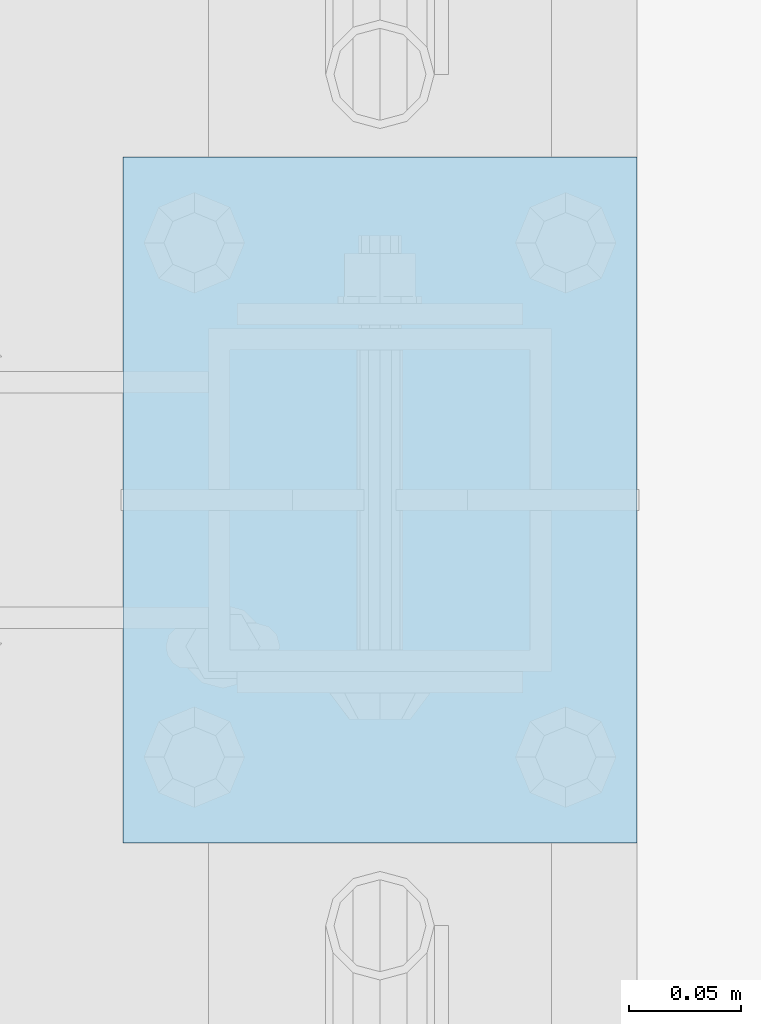
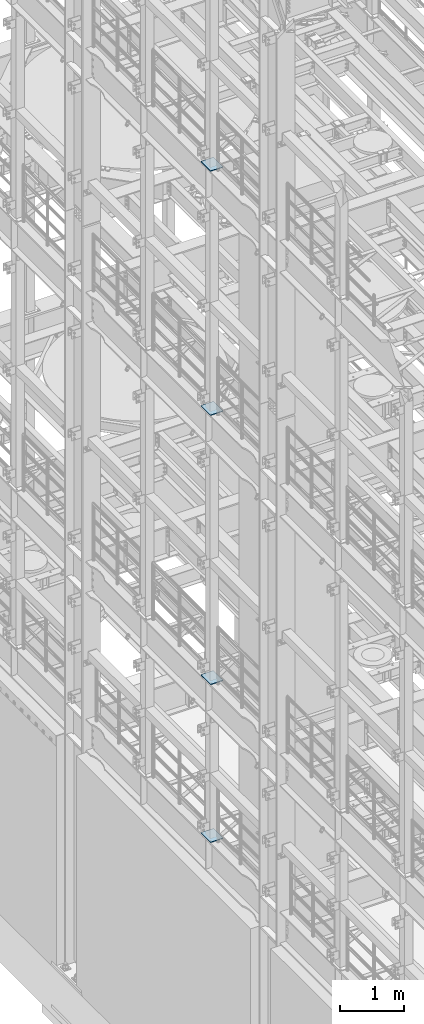
# One storey, part 1595 of 1876: 4 plates, 4 elements without a shape of their own.
"""IFC2X3 building model written with IfcOpenShell, lengths in millimetres."""

from ifc_helpers import new_model, si_unit, frame, origin_with_axes, place, context, subcontext, project, spatial, faceted_brep, material, type_object, element, aggregate, save


model = new_model("IFC2X3")

# Units and contexts
model_context = context("Model", 3, precision=1e-05, world=origin_with_axes())
body_context = subcontext(model_context, "Body", "Model", "MODEL_VIEW")
ifc_project = project(units=[si_unit("LENGTHUNIT", "METRE", prefix="MILLI"), si_unit("AREAUNIT", "SQUARE_METRE"), si_unit("VOLUMEUNIT", "CUBIC_METRE"), si_unit("MASSUNIT", "GRAM", prefix="KILO"), si_unit("TIMEUNIT", "SECOND"), si_unit("PLANEANGLEUNIT", "RADIAN"), si_unit("SOLIDANGLEUNIT", "STERADIAN"), si_unit("THERMODYNAMICTEMPERATUREUNIT", "DEGREE_CELSIUS"), si_unit("LUMINOUSINTENSITYUNIT", "LUMEN")], contexts=[model_context])

# Site, building, storey
site_placement = place(None, origin_with_axes())
site = spatial("IfcSite", under=ifc_project, at=site_placement, CompositionType="ELEMENT")
building_placement = place(site_placement, origin_with_axes())
building = spatial("IfcBuilding", under=site, at=building_placement, Name="Undefined", CompositionType="ELEMENT")
storey_placement = place(building_placement, origin_with_axes())
storey = spatial("IfcBuildingStorey", under=building, at=storey_placement, Name="Undefined", CompositionType="ELEMENT", Elevation=0.0)

# Assembly, plate
assembly_1_placement = place(storey_placement, origin_with_axes())
assembly_1 = element("IfcElementAssembly", 1, at=assembly_1_placement, inside=storey, Name="BEAM", AssemblyPlace="NOTDEFINED", PredefinedType="RIGID_FRAME")
ifc_material = material(Name="STEEL/A36")
plate_type = type_object("IfcPlateType", PredefinedType="NOTDEFINED")
plate_1_placement = place(assembly_1_placement, frame((-114.3, 3403.6, 17989.55), z_axis=(0.0, 1.0, 0.0), x_axis=(1.0, 0.0, 0.0)))
plate_1 = element("IfcPlate", 2, at=plate_1_placement, type_object=plate_type, material=ifc_material, Name="PLATE", context=body_context, shape_type="Brep", body=[
    faceted_brep([(0.0, -6.35000000000036, 0.0), (0.0, -6.35000000000036, 304.799987792969), (0.0, 6.35000000000036, 304.799987792969), (0.0, 6.35000000000036, 0.0), (228.600006103516, -6.34999999999854, 304.799987792969), (228.600006103516, 6.34999999999854, 304.799987792969), (228.600006103516, -6.34999999999854, 0.0), (228.600006103516, 6.34999999999854, 0.0)], [[[0, 1, 2, 3]], [[1, 4, 5, 2]], [[4, 6, 7, 5]], [[6, 0, 3, 7]], [[5, 7, 3, 2]], [[6, 4, 1, 0]]]),
])
aggregate(assembly_1, [plate_1])

assembly_2_placement = place(storey_placement, origin_with_axes())
assembly_2 = element("IfcElementAssembly", 3, at=assembly_2_placement, inside=storey, Name="BEAM", AssemblyPlace="NOTDEFINED", PredefinedType="RIGID_FRAME")
plate_2_placement = place(assembly_2_placement, frame((-114.3, 3403.6, 13315.95), z_axis=(0.0, 1.0, 0.0), x_axis=(1.0, 0.0, 0.0)))
plate_2 = element("IfcPlate", 4, at=plate_2_placement, type_object=plate_type, material=ifc_material, Name="PLATE", context=body_context, shape_type="Brep", body=[
    faceted_brep([(0.0, -6.35000000000036, 0.0), (0.0, -6.35000000000036, 304.799987792969), (0.0, 6.35000000000036, 304.799987792969), (0.0, 6.35000000000036, 0.0), (228.600006103516, -6.34999999999854, 304.799987792969), (228.600006103516, 6.34999999999854, 304.799987792969), (228.600006103516, -6.34999999999854, 0.0), (228.600006103516, 6.34999999999854, 0.0)], [[[0, 1, 2, 3]], [[1, 4, 5, 2]], [[4, 6, 7, 5]], [[6, 0, 3, 7]], [[5, 7, 3, 2]], [[6, 4, 1, 0]]]),
])
aggregate(assembly_2, [plate_2])

assembly_3_placement = place(storey_placement, origin_with_axes())
assembly_3 = element("IfcElementAssembly", 5, at=assembly_3_placement, inside=storey, Name="BEAM", AssemblyPlace="NOTDEFINED", PredefinedType="RIGID_FRAME")
plate_3_placement = place(assembly_3_placement, frame((-114.3, 3403.6, 8159.75), z_axis=(0.0, 1.0, 0.0), x_axis=(1.0, 0.0, 0.0)))
plate_3 = element("IfcPlate", 6, at=plate_3_placement, type_object=plate_type, material=ifc_material, Name="PLATE", context=body_context, shape_type="Brep", body=[
    faceted_brep([(0.0, -6.35000000000036, 0.0), (0.0, -6.35000000000036, 304.799987792969), (0.0, 6.35000000000036, 304.799987792969), (0.0, 6.35000000000036, 0.0), (228.600006103516, -6.34999999999854, 304.799987792969), (228.600006103516, 6.34999999999854, 304.799987792969), (228.600006103516, -6.34999999999854, 0.0), (228.600006103516, 6.34999999999854, 0.0)], [[[0, 1, 2, 3]], [[1, 4, 5, 2]], [[4, 6, 7, 5]], [[6, 0, 3, 7]], [[5, 7, 3, 2]], [[6, 4, 1, 0]]]),
])
aggregate(assembly_3, [plate_3])

assembly_4_placement = place(storey_placement, origin_with_axes())
assembly_4 = element("IfcElementAssembly", 7, at=assembly_4_placement, inside=storey, Name="BEAM", AssemblyPlace="NOTDEFINED", PredefinedType="RIGID_FRAME")
plate_4_placement = place(assembly_4_placement, frame((-114.3, 3403.6, 5137.15), z_axis=(0.0, 1.0, 0.0), x_axis=(1.0, 0.0, 0.0)))
plate_4 = element("IfcPlate", 8, at=plate_4_placement, type_object=plate_type, material=ifc_material, Name="PLATE", context=body_context, shape_type="Brep", body=[
    faceted_brep([(0.0, -6.35000000000036, 0.0), (0.0, -6.35000000000036, 304.799987792969), (0.0, 6.35000000000036, 304.799987792969), (0.0, 6.35000000000036, 0.0), (228.600006103516, -6.34999999999854, 304.799987792969), (228.600006103516, 6.34999999999854, 304.799987792969), (228.600006103516, -6.34999999999854, 0.0), (228.600006103516, 6.34999999999854, 0.0)], [[[0, 1, 2, 3]], [[1, 4, 5, 2]], [[4, 6, 7, 5]], [[6, 0, 3, 7]], [[5, 7, 3, 2]], [[6, 4, 1, 0]]]),
])
aggregate(assembly_4, [plate_4])

save(model, "model.ifc")
